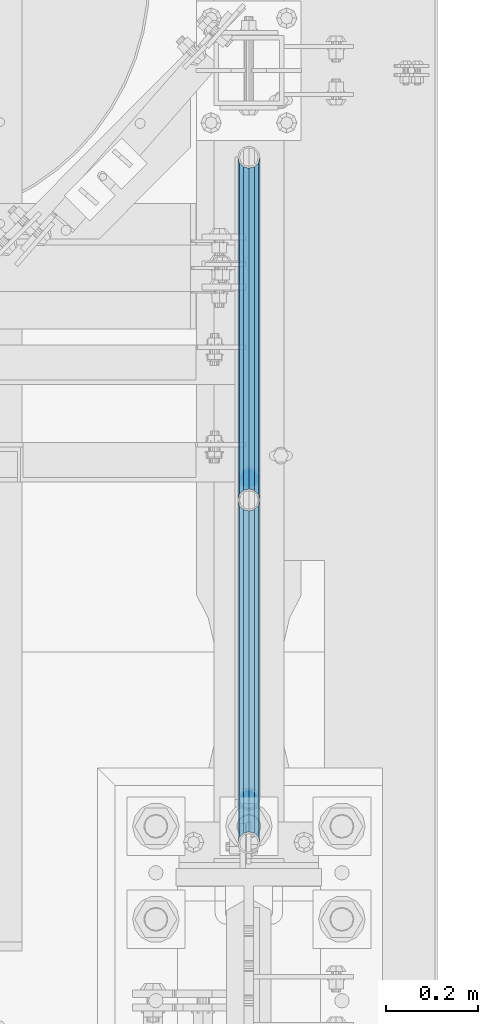
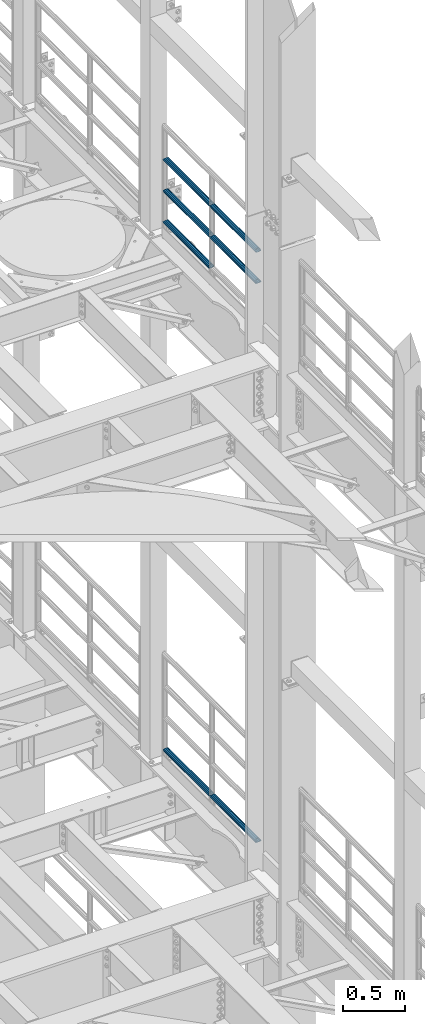
# One storey, part 1275 of 1876: 7 beams, 2 elements without a shape of their own.
"""IFC2X3 building model written with IfcOpenShell, lengths in millimetres."""

from ifc_helpers import new_model, si_unit, frame, origin_with_axes, place, context, subcontext, project, spatial, faceted_brep, material, type_object, element, aggregate, save


model = new_model("IFC2X3")

# Units and contexts
model_context = context("Model", 3, precision=1e-05, world=origin_with_axes())
body_context = subcontext(model_context, "Body", "Model", "MODEL_VIEW")
ifc_project = project(units=[si_unit("LENGTHUNIT", "METRE", prefix="MILLI"), si_unit("AREAUNIT", "SQUARE_METRE"), si_unit("VOLUMEUNIT", "CUBIC_METRE"), si_unit("MASSUNIT", "GRAM", prefix="KILO"), si_unit("TIMEUNIT", "SECOND"), si_unit("PLANEANGLEUNIT", "RADIAN"), si_unit("SOLIDANGLEUNIT", "STERADIAN"), si_unit("THERMODYNAMICTEMPERATUREUNIT", "DEGREE_CELSIUS"), si_unit("LUMINOUSINTENSITYUNIT", "LUMEN")], contexts=[model_context])

# Site, building, storey
site_placement = place(None, origin_with_axes())
site = spatial("IfcSite", under=ifc_project, at=site_placement, CompositionType="ELEMENT")
building_placement = place(site_placement, origin_with_axes())
building = spatial("IfcBuilding", under=site, at=building_placement, Name="Undefined", CompositionType="ELEMENT")
storey_placement = place(building_placement, origin_with_axes())
storey = spatial("IfcBuildingStorey", under=building, at=storey_placement, Name="Undefined", CompositionType="ELEMENT", Elevation=0.0)

# Assembly, beams
assembly_1_placement = place(storey_placement, origin_with_axes())
assembly_1 = element("IfcElementAssembly", 1, at=assembly_1_placement, inside=storey, Name="RAIL", AssemblyPlace="NOTDEFINED", PredefinedType="RIGID_FRAME")
ifc_material = material()
beam_type = type_object("IfcBeamType", Name="PIPE1-1/2SCH40", PredefinedType="NOTDEFINED")
beam_1_placement = place(assembly_1_placement, frame((7620.0, 3366.77, 13471.525), z_axis=(0.0, 0.0, 1.0), x_axis=(0.0, -1.0, 0.0)))
beam_1 = element("IfcBeam", 2, at=beam_1_placement, type_object=beam_type, material=ifc_material, Name="RAIL", ObjectType="PIPE1-1/2SCH40", context=body_context, shape_type="Brep", body=[
    faceted_brep([(728.085307006683, -12.0649999999996, 20.8971929933177), (728.085307006683, -12.0649999999996, 15.8661214311796), (727.591878568821, -10.2235000000001, 17.7076214311819), (724.852500000002, 0.0, 20.4470000000001), (724.852500000002, 0.0, 24.130000000001), (727.591878568821, 10.2235000000001, 17.7076214311819), (728.085307006683, 12.0649999999996, 15.8661214311796), (728.085307006683, 12.0649999999996, 20.8971929933177), (748.982500000002, 24.1300000000001, 0.0), (736.917500000002, 20.8971929933186, 12.0649999999987), (736.917500000002, 20.8971929933186, -12.0649999999987), (733.727928437864, 17.7076214311801, 10.2235000000001), (736.467307006683, 20.4470000000001, 0.0), (733.727928437864, 17.7076214311801, -10.2235000000001), (728.085307006683, 12.0649999999996, -15.8661214311796), (728.085307006683, 12.0649999999996, -20.8971929933177), (727.591878568821, 10.2235000000001, -17.7076214311819), (724.852500000002, 0.0, -20.4470000000001), (724.852500000002, 0.0, -24.130000000001), (728.085307006683, -12.0649999999996, -15.8661214311796), (728.085307006683, -12.0649999999996, -20.8971929933177), (727.591878568821, -10.2235000000001, -17.7076214311819), (748.982500000002, -24.1300000000001, 0.0), (736.917500000002, -20.8971929933186, -12.0649999999987), (736.917500000002, -20.8971929933186, 12.0649999999987), (733.727928437864, -17.7076214311801, -10.2235000000001), (736.467307006683, -20.4470000000001, 0.0), (733.727928437864, -17.7076214311801, 10.2235000000001), (12.0650000000064, -20.8971929933177, -12.0649999999987), (20.8971929933249, -12.0650000000005, -20.8971929933177), (0.0, 24.1299999999992, 0.0), (12.0650000000064, 20.8971929933177, -12.0649999999987), (12.0650000000064, 20.8971929933177, 12.0649999999987), (20.8971929933249, 12.0650000000005, 20.8971929933177), (24.1300000000064, 0.0, 24.130000000001), (20.8971929933249, 12.0650000000005, -20.8971929933177), (24.1300000000063, 0.0, -24.130000000001), (24.1300000000063, 0.0, -20.4470000000001), (20.8971929933249, -12.0650000000005, -15.8661214311796), (21.3906214311868, -10.2235000000001, -17.7076214311819), (21.3906214311868, 10.2235000000001, -17.7076214311819), (20.8971929933249, 12.0650000000005, -15.8661214311796), (15.2545715621445, 17.7076214311801, -10.2235000000001), (12.5151929933249, 20.4470000000001, 0.0), (15.2545715621445, 17.7076214311801, 10.2235000000001), (20.8971929933249, 12.0650000000005, 15.8661214311796), (21.3906214311868, 10.2235000000001, 17.7076214311819), (24.1300000000064, 0.0, 20.4470000000001), (21.3906214311868, -10.2235000000001, 17.7076214311819), (20.8971929933249, -12.0650000000005, 15.8661214311796), (20.8971929933249, -12.0650000000005, 20.8971929933177), (12.0650000000064, -20.8971929933177, 12.0649999999987), (0.0, -24.1299999999992, 0.0), (15.2545715621445, -17.7076214311801, 10.2235000000001), (12.5151929933249, -20.4470000000001, 0.0), (15.2545715621445, -17.7076214311801, -10.2235000000001)], [[[0, 1, 2, 3, 4]], [[4, 3, 5, 6, 7]], [[8, 9, 10]], [[7, 6, 11, 12, 13, 14, 15, 10, 9]], [[16, 17, 18, 15, 14]], [[19, 20, 18, 17, 21]], [[22, 23, 24]], [[24, 23, 20, 19, 25, 26, 27, 1, 0]], [[28, 29, 20, 23]], [[30, 31, 32]], [[33, 34, 4, 7]], [[32, 33, 7, 9]], [[30, 32, 9, 8]], [[31, 30, 8, 10]], [[35, 31, 10, 15]], [[36, 35, 15, 18]], [[29, 36, 18, 20]], [[37, 36, 29, 38, 39]], [[40, 41, 35, 36, 37]], [[32, 31, 35, 41, 42, 43, 44, 45, 33]], [[33, 45, 46, 47, 34]], [[34, 47, 48, 49, 50]], [[34, 50, 0, 4]], [[50, 51, 24, 0]], [[51, 52, 22, 24]], [[52, 28, 23, 22]], [[51, 28, 52]], [[50, 49, 53, 54, 55, 38, 29, 28, 51]], [[55, 54, 26, 25]], [[21, 39, 38, 55, 25, 19]], [[37, 39, 21, 17]], [[40, 37, 17, 16]], [[42, 41, 40, 16, 14, 13]], [[43, 42, 13, 12]], [[44, 43, 12, 11]], [[5, 46, 45, 44, 11, 6]], [[47, 46, 5, 3]], [[48, 47, 3, 2]], [[53, 49, 48, 2, 1, 27]], [[54, 53, 27, 26]]]),
])
beam_2_placement = place(assembly_1_placement, frame((7620.0, 1868.805, 13776.325), z_axis=(0.0, 0.0, -1.0), x_axis=(0.0, 1.0, 0.0)))
beam_2 = element("IfcBeam", 3, at=beam_2_placement, type_object=beam_type, material=ifc_material, Name="RAIL", ObjectType="PIPE1-1/2SCH40", context=body_context, shape_type="Brep", body=[
    faceted_brep([(0.0, 24.1299999999992, 0.0), (12.0650000000064, 20.8971929933177, -12.0649999999987), (12.0650000000064, 20.8971929933177, 12.0649999999987), (12.0650000000064, -20.8971929933177, 12.0649999999987), (12.0650000000064, -20.8971929933177, -12.0649999999987), (0.0, -24.1299999999992, 0.0), (20.8971929933249, -12.0650000000005, 20.8971929933177), (20.8971929933249, -12.0650000000005, 15.8661214311796), (15.2545715621445, -17.7076214311801, 10.2235000000001), (12.5151929933249, -20.4470000000001, 0.0), (15.2545715621445, -17.7076214311801, -10.2235000000001), (20.8971929933249, -12.0650000000005, -15.8661214311796), (20.8971929933249, -12.0650000000005, -20.8971929933177), (24.1300000000063, 0.0, -20.4470000000001), (24.1300000000063, 0.0, -24.130000000001), (21.3906214311868, -10.2235000000001, -17.7076214311819), (21.3906214311868, 10.2235000000001, -17.7076214311819), (20.8971929933249, 12.0650000000005, -15.8661214311796), (20.8971929933249, 12.0650000000005, -20.8971929933177), (15.2545715621445, 17.7076214311801, -10.2235000000001), (12.5151929933249, 20.4470000000001, 0.0), (15.2545715621445, 17.7076214311801, 10.2235000000001), (20.8971929933249, 12.0650000000005, 15.8661214311796), (20.8971929933249, 12.0650000000005, 20.8971929933177), (21.3906214311868, 10.2235000000001, 17.7076214311819), (24.1300000000064, 0.0, 20.4470000000001), (24.1300000000064, 0.0, 24.130000000001), (21.3906214311868, -10.2235000000001, 17.7076214311819), (748.982500000002, 24.1300000000001, 0.0), (736.917500000002, 20.8971929933186, -12.0649999999987), (728.085307006683, 12.0649999999996, -20.8971929933177), (748.982500000002, -24.1300000000001, 0.0), (736.917500000002, -20.8971929933186, -12.0649999999987), (736.917500000002, -20.8971929933186, 12.0649999999987), (728.085307006683, -12.0649999999996, 20.8971929933177), (728.085307006683, -12.0649999999996, -20.8971929933177), (724.852500000002, 0.0, -24.130000000001), (727.591878568821, 10.2235000000001, -17.7076214311819), (724.852500000002, 0.0, -20.4470000000001), (728.085307006683, 12.0649999999996, -15.8661214311796), (728.085307006683, -12.0649999999996, -15.8661214311796), (727.591878568821, -10.2235000000001, -17.7076214311819), (733.727928437864, -17.7076214311801, -10.2235000000001), (736.467307006683, -20.4470000000001, 0.0), (733.727928437864, -17.7076214311801, 10.2235000000001), (728.085307006683, -12.0649999999996, 15.8661214311796), (727.591878568821, -10.2235000000001, 17.7076214311819), (724.852500000002, 0.0, 20.4470000000001), (724.852500000002, 0.0, 24.130000000001), (728.085307006683, 12.0649999999996, 20.8971929933177), (736.917500000002, 20.8971929933186, 12.0649999999987), (728.085307006683, 12.0649999999996, 15.8661214311796), (733.727928437864, 17.7076214311801, 10.2235000000001), (736.467307006683, 20.4470000000001, 0.0), (733.727928437864, 17.7076214311801, -10.2235000000001), (727.591878568821, 10.2235000000001, 17.7076214311819)], [[[0, 1, 2]], [[3, 4, 5]], [[6, 7, 8, 9, 10, 11, 12, 4, 3]], [[13, 14, 12, 11, 15]], [[16, 17, 18, 14, 13]], [[2, 1, 18, 17, 19, 20, 21, 22, 23]], [[23, 22, 24, 25, 26]], [[26, 25, 27, 7, 6]], [[1, 0, 28, 29]], [[18, 1, 29, 30]], [[31, 32, 33]], [[6, 3, 33, 34]], [[3, 5, 31, 33]], [[5, 4, 32, 31]], [[4, 12, 35, 32]], [[12, 14, 36, 35]], [[14, 18, 30, 36]], [[37, 38, 36, 30, 39]], [[40, 35, 36, 38, 41]], [[33, 32, 35, 40, 42, 43, 44, 45, 34]], [[34, 45, 46, 47, 48]], [[26, 6, 34, 48]], [[2, 23, 49, 50]], [[23, 26, 48, 49]], [[0, 2, 50, 28]], [[28, 50, 29]], [[49, 51, 52, 53, 54, 39, 30, 29, 50]], [[48, 47, 55, 51, 49]], [[25, 24, 55, 47]], [[55, 24, 22, 21, 52, 51]], [[21, 20, 53, 52]], [[20, 19, 54, 53]], [[19, 17, 16, 37, 39, 54]], [[16, 13, 38, 37]], [[13, 15, 41, 38]], [[41, 15, 11, 10, 42, 40]], [[10, 9, 43, 42]], [[9, 8, 44, 43]], [[8, 7, 27, 46, 45, 44]], [[27, 25, 47, 46]]]),
])
beam_3_placement = place(assembly_1_placement, frame((7620.0, 2617.7875, 13776.325), z_axis=(0.0, 0.0, -1.0), x_axis=(0.0, 1.0, 0.0)))
beam_3 = element("IfcBeam", 4, at=beam_3_placement, type_object=beam_type, material=ifc_material, Name="RAIL", ObjectType="PIPE1-1/2SCH40", context=body_context, shape_type="Brep", body=[
    faceted_brep([(0.0, 24.1299999999992, 0.0), (12.0650000000064, 20.8971929933177, -12.0649999999987), (12.0650000000064, 20.8971929933177, 12.0649999999987), (12.0650000000064, -20.8971929933177, 12.0649999999987), (12.0650000000064, -20.8971929933177, -12.0649999999987), (0.0, -24.1299999999992, 0.0), (20.8971929933249, -12.0650000000005, 20.8971929933177), (20.8971929933249, -12.0650000000005, 15.8661214311796), (15.2545715621445, -17.7076214311801, 10.2235000000001), (12.5151929933249, -20.4470000000001, 0.0), (15.2545715621445, -17.7076214311801, -10.2235000000001), (20.8971929933249, -12.0650000000005, -15.8661214311796), (20.8971929933249, -12.0650000000005, -20.8971929933177), (24.1300000000063, 0.0, -20.4470000000001), (24.1300000000063, 0.0, -24.130000000001), (21.3906214311868, -10.2235000000001, -17.7076214311819), (21.3906214311868, 10.2235000000001, -17.7076214311819), (20.8971929933249, 12.0650000000005, -15.8661214311796), (20.8971929933249, 12.0650000000005, -20.8971929933177), (15.2545715621445, 17.7076214311801, -10.2235000000001), (12.5151929933249, 20.4470000000001, 0.0), (15.2545715621445, 17.7076214311801, 10.2235000000001), (20.8971929933249, 12.0650000000005, 15.8661214311796), (20.8971929933249, 12.0650000000005, 20.8971929933177), (21.3906214311868, 10.2235000000001, 17.7076214311819), (24.1300000000064, 0.0, 20.4470000000001), (24.1300000000064, 0.0, 24.130000000001), (21.3906214311868, -10.2235000000001, 17.7076214311819), (748.982500000002, 24.1300000000001, 0.0), (736.917500000002, 20.8971929933186, -12.0649999999987), (728.085307006683, 12.0649999999996, -20.8971929933177), (748.982500000002, -24.1300000000001, 0.0), (736.917500000002, -20.8971929933186, -12.0649999999987), (736.917500000002, -20.8971929933186, 12.0649999999987), (728.085307006683, -12.0649999999996, 20.8971929933177), (728.085307006683, -12.0649999999996, -20.8971929933177), (724.852500000002, 0.0, -24.130000000001), (727.591878568821, 10.2235000000001, -17.7076214311819), (724.852500000002, 0.0, -20.4470000000001), (728.085307006683, 12.0649999999996, -15.8661214311796), (728.085307006683, -12.0649999999996, -15.8661214311796), (727.591878568821, -10.2235000000001, -17.7076214311819), (733.727928437864, -17.7076214311801, -10.2235000000001), (736.467307006683, -20.4470000000001, 0.0), (733.727928437864, -17.7076214311801, 10.2235000000001), (728.085307006683, -12.0649999999996, 15.8661214311796), (727.591878568821, -10.2235000000001, 17.7076214311819), (724.852500000002, 0.0, 20.4470000000001), (724.852500000002, 0.0, 24.130000000001), (728.085307006683, 12.0649999999996, 20.8971929933177), (736.917500000002, 20.8971929933186, 12.0649999999987), (728.085307006683, 12.0649999999996, 15.8661214311796), (733.727928437864, 17.7076214311801, 10.2235000000001), (736.467307006683, 20.4470000000001, 0.0), (733.727928437864, 17.7076214311801, -10.2235000000001), (727.591878568821, 10.2235000000001, 17.7076214311819)], [[[0, 1, 2]], [[3, 4, 5]], [[6, 7, 8, 9, 10, 11, 12, 4, 3]], [[13, 14, 12, 11, 15]], [[16, 17, 18, 14, 13]], [[2, 1, 18, 17, 19, 20, 21, 22, 23]], [[23, 22, 24, 25, 26]], [[26, 25, 27, 7, 6]], [[1, 0, 28, 29]], [[18, 1, 29, 30]], [[31, 32, 33]], [[6, 3, 33, 34]], [[3, 5, 31, 33]], [[5, 4, 32, 31]], [[4, 12, 35, 32]], [[12, 14, 36, 35]], [[14, 18, 30, 36]], [[37, 38, 36, 30, 39]], [[40, 35, 36, 38, 41]], [[33, 32, 35, 40, 42, 43, 44, 45, 34]], [[34, 45, 46, 47, 48]], [[26, 6, 34, 48]], [[2, 23, 49, 50]], [[23, 26, 48, 49]], [[0, 2, 50, 28]], [[28, 50, 29]], [[49, 51, 52, 53, 54, 39, 30, 29, 50]], [[48, 47, 55, 51, 49]], [[25, 24, 55, 47]], [[55, 24, 22, 21, 52, 51]], [[21, 20, 53, 52]], [[20, 19, 54, 53]], [[19, 17, 16, 37, 39, 54]], [[16, 13, 38, 37]], [[13, 15, 41, 38]], [[41, 15, 11, 10, 42, 40]], [[10, 9, 43, 42]], [[9, 8, 44, 43]], [[8, 7, 27, 46, 45, 44]], [[27, 25, 47, 46]]]),
])
beam_4_placement = place(assembly_1_placement, frame((7620.0, 1868.805, 14081.125), z_axis=(0.0, 0.0, -1.0), x_axis=(0.0, 1.0, 0.0)))
beam_4 = element("IfcBeam", 5, at=beam_4_placement, type_object=beam_type, material=ifc_material, Name="RAIL", ObjectType="PIPE1-1/2SCH40", context=body_context, shape_type="Brep", body=[
    faceted_brep([(0.0, 24.1299999999992, 0.0), (12.0650000000064, 20.8971929933177, -12.0649999999987), (12.0650000000064, 20.8971929933177, 12.0649999999987), (12.0650000000064, -20.8971929933177, 12.0649999999987), (12.0650000000064, -20.8971929933177, -12.0649999999987), (0.0, -24.1299999999992, 0.0), (20.8971929933249, -12.0650000000005, 20.8971929933177), (20.8971929933249, -12.0650000000005, 15.8661214311796), (15.2545715621445, -17.7076214311801, 10.2235000000001), (12.5151929933249, -20.4470000000001, 0.0), (15.2545715621445, -17.7076214311801, -10.2235000000001), (20.8971929933249, -12.0650000000005, -15.8661214311796), (20.8971929933249, -12.0650000000005, -20.8971929933177), (24.1300000000063, 0.0, -20.4470000000001), (24.1300000000063, 0.0, -24.130000000001), (21.3906214311868, -10.2235000000001, -17.7076214311819), (21.3906214311868, 10.2235000000001, -17.7076214311819), (20.8971929933249, 12.0650000000005, -15.8661214311796), (20.8971929933249, 12.0650000000005, -20.8971929933177), (15.2545715621445, 17.7076214311801, -10.2235000000001), (12.5151929933249, 20.4470000000001, 0.0), (15.2545715621445, 17.7076214311801, 10.2235000000001), (20.8971929933249, 12.0650000000005, 15.8661214311796), (20.8971929933249, 12.0650000000005, 20.8971929933177), (21.3906214311868, 10.2235000000001, 17.7076214311819), (24.1300000000064, 0.0, 20.4470000000001), (24.1300000000064, 0.0, 24.130000000001), (21.3906214311868, -10.2235000000001, 17.7076214311819), (748.982500000002, 24.1300000000001, 0.0), (736.917500000002, 20.8971929933186, -12.0649999999987), (728.085307006683, 12.0649999999996, -20.8971929933177), (748.982500000002, -24.1300000000001, 0.0), (736.917500000002, -20.8971929933186, -12.0649999999987), (736.917500000002, -20.8971929933186, 12.0649999999987), (728.085307006683, -12.0649999999996, 20.8971929933177), (728.085307006683, -12.0649999999996, -20.8971929933177), (724.852500000002, 0.0, -24.130000000001), (727.591878568821, 10.2235000000001, -17.7076214311819), (724.852500000002, 0.0, -20.4470000000001), (728.085307006683, 12.0649999999996, -15.8661214311796), (728.085307006683, -12.0649999999996, -15.8661214311796), (727.591878568821, -10.2235000000001, -17.7076214311819), (733.727928437864, -17.7076214311801, -10.2235000000001), (736.467307006683, -20.4470000000001, 0.0), (733.727928437864, -17.7076214311801, 10.2235000000001), (728.085307006683, -12.0649999999996, 15.8661214311796), (727.591878568821, -10.2235000000001, 17.7076214311819), (724.852500000002, 0.0, 20.4470000000001), (724.852500000002, 0.0, 24.130000000001), (728.085307006683, 12.0649999999996, 20.8971929933177), (736.917500000002, 20.8971929933186, 12.0649999999987), (728.085307006683, 12.0649999999996, 15.8661214311796), (733.727928437864, 17.7076214311801, 10.2235000000001), (736.467307006683, 20.4470000000001, 0.0), (733.727928437864, 17.7076214311801, -10.2235000000001), (727.591878568821, 10.2235000000001, 17.7076214311819)], [[[0, 1, 2]], [[3, 4, 5]], [[6, 7, 8, 9, 10, 11, 12, 4, 3]], [[13, 14, 12, 11, 15]], [[16, 17, 18, 14, 13]], [[2, 1, 18, 17, 19, 20, 21, 22, 23]], [[23, 22, 24, 25, 26]], [[26, 25, 27, 7, 6]], [[1, 0, 28, 29]], [[18, 1, 29, 30]], [[31, 32, 33]], [[6, 3, 33, 34]], [[3, 5, 31, 33]], [[5, 4, 32, 31]], [[4, 12, 35, 32]], [[12, 14, 36, 35]], [[14, 18, 30, 36]], [[37, 38, 36, 30, 39]], [[40, 35, 36, 38, 41]], [[33, 32, 35, 40, 42, 43, 44, 45, 34]], [[34, 45, 46, 47, 48]], [[26, 6, 34, 48]], [[2, 23, 49, 50]], [[23, 26, 48, 49]], [[0, 2, 50, 28]], [[28, 50, 29]], [[49, 51, 52, 53, 54, 39, 30, 29, 50]], [[48, 47, 55, 51, 49]], [[25, 24, 55, 47]], [[55, 24, 22, 21, 52, 51]], [[21, 20, 53, 52]], [[20, 19, 54, 53]], [[19, 17, 16, 37, 39, 54]], [[16, 13, 38, 37]], [[13, 15, 41, 38]], [[41, 15, 11, 10, 42, 40]], [[10, 9, 43, 42]], [[9, 8, 44, 43]], [[8, 7, 27, 46, 45, 44]], [[27, 25, 47, 46]]]),
])
beam_5_placement = place(assembly_1_placement, frame((7620.0, 2617.7875, 14081.125), z_axis=(0.0, 0.0, -1.0), x_axis=(0.0, 1.0, 0.0)))
beam_5 = element("IfcBeam", 6, at=beam_5_placement, type_object=beam_type, material=ifc_material, Name="RAIL", ObjectType="PIPE1-1/2SCH40", context=body_context, shape_type="Brep", body=[
    faceted_brep([(0.0, 24.1299999999992, 0.0), (12.0650000000064, 20.8971929933177, -12.0649999999987), (12.0650000000064, 20.8971929933177, 12.0649999999987), (12.0650000000064, -20.8971929933177, 12.0649999999987), (12.0650000000064, -20.8971929933177, -12.0649999999987), (0.0, -24.1299999999992, 0.0), (20.8971929933249, -12.0650000000005, 20.8971929933177), (20.8971929933249, -12.0650000000005, 15.8661214311796), (15.2545715621445, -17.7076214311801, 10.2235000000001), (12.5151929933249, -20.4470000000001, 0.0), (15.2545715621445, -17.7076214311801, -10.2235000000001), (20.8971929933249, -12.0650000000005, -15.8661214311796), (20.8971929933249, -12.0650000000005, -20.8971929933177), (24.1300000000063, 0.0, -20.4470000000001), (24.1300000000063, 0.0, -24.130000000001), (21.3906214311868, -10.2235000000001, -17.7076214311819), (21.3906214311868, 10.2235000000001, -17.7076214311819), (20.8971929933249, 12.0650000000005, -15.8661214311796), (20.8971929933249, 12.0650000000005, -20.8971929933177), (15.2545715621445, 17.7076214311801, -10.2235000000001), (12.5151929933249, 20.4470000000001, 0.0), (15.2545715621445, 17.7076214311801, 10.2235000000001), (20.8971929933249, 12.0650000000005, 15.8661214311796), (20.8971929933249, 12.0650000000005, 20.8971929933177), (21.3906214311868, 10.2235000000001, 17.7076214311819), (24.1300000000064, 0.0, 20.4470000000001), (24.1300000000064, 0.0, 24.130000000001), (21.3906214311868, -10.2235000000001, 17.7076214311819), (748.982500000002, 24.1300000000001, 0.0), (736.917500000002, 20.8971929933186, -12.0649999999987), (728.085307006683, 12.0649999999996, -20.8971929933177), (748.982500000002, -24.1300000000001, 0.0), (736.917500000002, -20.8971929933186, -12.0649999999987), (736.917500000002, -20.8971929933186, 12.0649999999987), (728.085307006683, -12.0649999999996, 20.8971929933177), (728.085307006683, -12.0649999999996, -20.8971929933177), (724.852500000002, 0.0, -24.130000000001), (727.591878568821, 10.2235000000001, -17.7076214311819), (724.852500000002, 0.0, -20.4470000000001), (728.085307006683, 12.0649999999996, -15.8661214311796), (728.085307006683, -12.0649999999996, -15.8661214311796), (727.591878568821, -10.2235000000001, -17.7076214311819), (733.727928437864, -17.7076214311801, -10.2235000000001), (736.467307006683, -20.4470000000001, 0.0), (733.727928437864, -17.7076214311801, 10.2235000000001), (728.085307006683, -12.0649999999996, 15.8661214311796), (727.591878568821, -10.2235000000001, 17.7076214311819), (724.852500000002, 0.0, 20.4470000000001), (724.852500000002, 0.0, 24.130000000001), (728.085307006683, 12.0649999999996, 20.8971929933177), (736.917500000002, 20.8971929933186, 12.0649999999987), (728.085307006683, 12.0649999999996, 15.8661214311796), (733.727928437864, 17.7076214311801, 10.2235000000001), (736.467307006683, 20.4470000000001, 0.0), (733.727928437864, 17.7076214311801, -10.2235000000001), (727.591878568821, 10.2235000000001, 17.7076214311819)], [[[0, 1, 2]], [[3, 4, 5]], [[6, 7, 8, 9, 10, 11, 12, 4, 3]], [[13, 14, 12, 11, 15]], [[16, 17, 18, 14, 13]], [[2, 1, 18, 17, 19, 20, 21, 22, 23]], [[23, 22, 24, 25, 26]], [[26, 25, 27, 7, 6]], [[1, 0, 28, 29]], [[18, 1, 29, 30]], [[31, 32, 33]], [[6, 3, 33, 34]], [[3, 5, 31, 33]], [[5, 4, 32, 31]], [[4, 12, 35, 32]], [[12, 14, 36, 35]], [[14, 18, 30, 36]], [[37, 38, 36, 30, 39]], [[40, 35, 36, 38, 41]], [[33, 32, 35, 40, 42, 43, 44, 45, 34]], [[34, 45, 46, 47, 48]], [[26, 6, 34, 48]], [[2, 23, 49, 50]], [[23, 26, 48, 49]], [[0, 2, 50, 28]], [[28, 50, 29]], [[49, 51, 52, 53, 54, 39, 30, 29, 50]], [[48, 47, 55, 51, 49]], [[25, 24, 55, 47]], [[55, 24, 22, 21, 52, 51]], [[21, 20, 53, 52]], [[20, 19, 54, 53]], [[19, 17, 16, 37, 39, 54]], [[16, 13, 38, 37]], [[13, 15, 41, 38]], [[41, 15, 11, 10, 42, 40]], [[10, 9, 43, 42]], [[9, 8, 44, 43]], [[8, 7, 27, 46, 45, 44]], [[27, 25, 47, 46]]]),
])
aggregate(assembly_1, [beam_1, beam_2, beam_3, beam_4, beam_5])

assembly_2_placement = place(storey_placement, origin_with_axes())
assembly_2 = element("IfcElementAssembly", 7, at=assembly_2_placement, inside=storey, Name="RAIL", AssemblyPlace="NOTDEFINED", PredefinedType="RIGID_FRAME")
beam_6_placement = place(assembly_2_placement, frame((7620.0, 2617.7875, 8315.325), z_axis=(0.0, 0.0, 1.0), x_axis=(0.0, -1.0, 0.0)))
beam_6 = element("IfcBeam", 8, at=beam_6_placement, type_object=beam_type, material=ifc_material, Name="RAIL", ObjectType="PIPE1-1/2SCH40", context=body_context, shape_type="Brep", body=[
    faceted_brep([(728.085307006683, -12.0649999999996, 20.8971929933177), (728.085307006683, -12.0649999999996, 15.8661214311796), (727.591878568821, -10.2235000000001, 17.7076214311819), (724.852500000002, 0.0, 20.4470000000001), (724.852500000002, 0.0, 24.130000000001), (727.591878568821, 10.2235000000001, 17.7076214311819), (728.085307006683, 12.0649999999996, 15.8661214311796), (728.085307006683, 12.0649999999996, 20.8971929933177), (748.982500000002, 24.1300000000001, 0.0), (736.917500000002, 20.8971929933186, 12.0649999999987), (736.917500000002, 20.8971929933186, -12.0649999999987), (733.727928437864, 17.7076214311801, 10.2235000000001), (736.467307006683, 20.4470000000001, 0.0), (733.727928437864, 17.7076214311801, -10.2235000000001), (728.085307006683, 12.0649999999996, -15.8661214311796), (728.085307006683, 12.0649999999996, -20.8971929933177), (727.591878568821, 10.2235000000001, -17.7076214311819), (724.852500000002, 0.0, -20.4470000000001), (724.852500000002, 0.0, -24.130000000001), (728.085307006683, -12.0649999999996, -15.8661214311796), (728.085307006683, -12.0649999999996, -20.8971929933177), (727.591878568821, -10.2235000000001, -17.7076214311819), (748.982500000002, -24.1300000000001, 0.0), (736.917500000002, -20.8971929933186, -12.0649999999987), (736.917500000002, -20.8971929933186, 12.0649999999987), (733.727928437864, -17.7076214311801, -10.2235000000001), (736.467307006683, -20.4470000000001, 0.0), (733.727928437864, -17.7076214311801, 10.2235000000001), (12.0650000000064, -20.8971929933177, -12.0649999999987), (20.8971929933249, -12.0650000000005, -20.8971929933177), (0.0, 24.1299999999992, 0.0), (12.0650000000064, 20.8971929933177, -12.0649999999987), (12.0650000000064, 20.8971929933177, 12.0649999999987), (20.8971929933249, 12.0650000000005, 20.8971929933177), (24.1300000000064, 0.0, 24.130000000001), (20.8971929933249, 12.0650000000005, -20.8971929933177), (24.1300000000063, 0.0, -24.130000000001), (24.1300000000063, 0.0, -20.4470000000001), (20.8971929933249, -12.0650000000005, -15.8661214311796), (21.3906214311868, -10.2235000000001, -17.7076214311819), (21.3906214311868, 10.2235000000001, -17.7076214311819), (20.8971929933249, 12.0650000000005, -15.8661214311796), (15.2545715621445, 17.7076214311801, -10.2235000000001), (12.5151929933249, 20.4470000000001, 0.0), (15.2545715621445, 17.7076214311801, 10.2235000000001), (20.8971929933249, 12.0650000000005, 15.8661214311796), (21.3906214311868, 10.2235000000001, 17.7076214311819), (24.1300000000064, 0.0, 20.4470000000001), (21.3906214311868, -10.2235000000001, 17.7076214311819), (20.8971929933249, -12.0650000000005, 15.8661214311796), (20.8971929933249, -12.0650000000005, 20.8971929933177), (12.0650000000064, -20.8971929933177, 12.0649999999987), (0.0, -24.1299999999992, 0.0), (15.2545715621445, -17.7076214311801, 10.2235000000001), (12.5151929933249, -20.4470000000001, 0.0), (15.2545715621445, -17.7076214311801, -10.2235000000001)], [[[0, 1, 2, 3, 4]], [[4, 3, 5, 6, 7]], [[8, 9, 10]], [[7, 6, 11, 12, 13, 14, 15, 10, 9]], [[16, 17, 18, 15, 14]], [[19, 20, 18, 17, 21]], [[22, 23, 24]], [[24, 23, 20, 19, 25, 26, 27, 1, 0]], [[28, 29, 20, 23]], [[30, 31, 32]], [[33, 34, 4, 7]], [[32, 33, 7, 9]], [[30, 32, 9, 8]], [[31, 30, 8, 10]], [[35, 31, 10, 15]], [[36, 35, 15, 18]], [[29, 36, 18, 20]], [[37, 36, 29, 38, 39]], [[40, 41, 35, 36, 37]], [[32, 31, 35, 41, 42, 43, 44, 45, 33]], [[33, 45, 46, 47, 34]], [[34, 47, 48, 49, 50]], [[34, 50, 0, 4]], [[50, 51, 24, 0]], [[51, 52, 22, 24]], [[52, 28, 23, 22]], [[51, 28, 52]], [[50, 49, 53, 54, 55, 38, 29, 28, 51]], [[55, 54, 26, 25]], [[21, 39, 38, 55, 25, 19]], [[37, 39, 21, 17]], [[40, 37, 17, 16]], [[42, 41, 40, 16, 14, 13]], [[43, 42, 13, 12]], [[44, 43, 12, 11]], [[5, 46, 45, 44, 11, 6]], [[47, 46, 5, 3]], [[48, 47, 3, 2]], [[53, 49, 48, 2, 1, 27]], [[54, 53, 27, 26]]]),
])
beam_7_placement = place(assembly_2_placement, frame((7620.0, 3366.77, 8315.325), z_axis=(0.0, 0.0, 1.0), x_axis=(0.0, -1.0, 0.0)))
beam_7 = element("IfcBeam", 9, at=beam_7_placement, type_object=beam_type, material=ifc_material, Name="RAIL", ObjectType="PIPE1-1/2SCH40", context=body_context, shape_type="Brep", body=[
    faceted_brep([(728.085307006683, -12.0649999999996, 20.8971929933177), (728.085307006683, -12.0649999999996, 15.8661214311796), (727.591878568821, -10.2235000000001, 17.7076214311819), (724.852500000002, 0.0, 20.4470000000001), (724.852500000002, 0.0, 24.130000000001), (727.591878568821, 10.2235000000001, 17.7076214311819), (728.085307006683, 12.0649999999996, 15.8661214311796), (728.085307006683, 12.0649999999996, 20.8971929933177), (748.982500000002, 24.1300000000001, 0.0), (736.917500000002, 20.8971929933186, 12.0649999999987), (736.917500000002, 20.8971929933186, -12.0649999999987), (733.727928437864, 17.7076214311801, 10.2235000000001), (736.467307006683, 20.4470000000001, 0.0), (733.727928437864, 17.7076214311801, -10.2235000000001), (728.085307006683, 12.0649999999996, -15.8661214311796), (728.085307006683, 12.0649999999996, -20.8971929933177), (727.591878568821, 10.2235000000001, -17.7076214311819), (724.852500000002, 0.0, -20.4470000000001), (724.852500000002, 0.0, -24.130000000001), (728.085307006683, -12.0649999999996, -15.8661214311796), (728.085307006683, -12.0649999999996, -20.8971929933177), (727.591878568821, -10.2235000000001, -17.7076214311819), (748.982500000002, -24.1300000000001, 0.0), (736.917500000002, -20.8971929933186, -12.0649999999987), (736.917500000002, -20.8971929933186, 12.0649999999987), (733.727928437864, -17.7076214311801, -10.2235000000001), (736.467307006683, -20.4470000000001, 0.0), (733.727928437864, -17.7076214311801, 10.2235000000001), (12.0650000000064, -20.8971929933177, -12.0649999999987), (20.8971929933249, -12.0650000000005, -20.8971929933177), (0.0, 24.1299999999992, 0.0), (12.0650000000064, 20.8971929933177, -12.0649999999987), (12.0650000000064, 20.8971929933177, 12.0649999999987), (20.8971929933249, 12.0650000000005, 20.8971929933177), (24.1300000000064, 0.0, 24.130000000001), (20.8971929933249, 12.0650000000005, -20.8971929933177), (24.1300000000063, 0.0, -24.130000000001), (24.1300000000063, 0.0, -20.4470000000001), (20.8971929933249, -12.0650000000005, -15.8661214311796), (21.3906214311868, -10.2235000000001, -17.7076214311819), (21.3906214311868, 10.2235000000001, -17.7076214311819), (20.8971929933249, 12.0650000000005, -15.8661214311796), (15.2545715621445, 17.7076214311801, -10.2235000000001), (12.5151929933249, 20.4470000000001, 0.0), (15.2545715621445, 17.7076214311801, 10.2235000000001), (20.8971929933249, 12.0650000000005, 15.8661214311796), (21.3906214311868, 10.2235000000001, 17.7076214311819), (24.1300000000064, 0.0, 20.4470000000001), (21.3906214311868, -10.2235000000001, 17.7076214311819), (20.8971929933249, -12.0650000000005, 15.8661214311796), (20.8971929933249, -12.0650000000005, 20.8971929933177), (12.0650000000064, -20.8971929933177, 12.0649999999987), (0.0, -24.1299999999992, 0.0), (15.2545715621445, -17.7076214311801, 10.2235000000001), (12.5151929933249, -20.4470000000001, 0.0), (15.2545715621445, -17.7076214311801, -10.2235000000001)], [[[0, 1, 2, 3, 4]], [[4, 3, 5, 6, 7]], [[8, 9, 10]], [[7, 6, 11, 12, 13, 14, 15, 10, 9]], [[16, 17, 18, 15, 14]], [[19, 20, 18, 17, 21]], [[22, 23, 24]], [[24, 23, 20, 19, 25, 26, 27, 1, 0]], [[28, 29, 20, 23]], [[30, 31, 32]], [[33, 34, 4, 7]], [[32, 33, 7, 9]], [[30, 32, 9, 8]], [[31, 30, 8, 10]], [[35, 31, 10, 15]], [[36, 35, 15, 18]], [[29, 36, 18, 20]], [[37, 36, 29, 38, 39]], [[40, 41, 35, 36, 37]], [[32, 31, 35, 41, 42, 43, 44, 45, 33]], [[33, 45, 46, 47, 34]], [[34, 47, 48, 49, 50]], [[34, 50, 0, 4]], [[50, 51, 24, 0]], [[51, 52, 22, 24]], [[52, 28, 23, 22]], [[51, 28, 52]], [[50, 49, 53, 54, 55, 38, 29, 28, 51]], [[55, 54, 26, 25]], [[21, 39, 38, 55, 25, 19]], [[37, 39, 21, 17]], [[40, 37, 17, 16]], [[42, 41, 40, 16, 14, 13]], [[43, 42, 13, 12]], [[44, 43, 12, 11]], [[5, 46, 45, 44, 11, 6]], [[47, 46, 5, 3]], [[48, 47, 3, 2]], [[53, 49, 48, 2, 1, 27]], [[54, 53, 27, 26]]]),
])
aggregate(assembly_2, [beam_6, beam_7])

save(model, "model.ifc")
